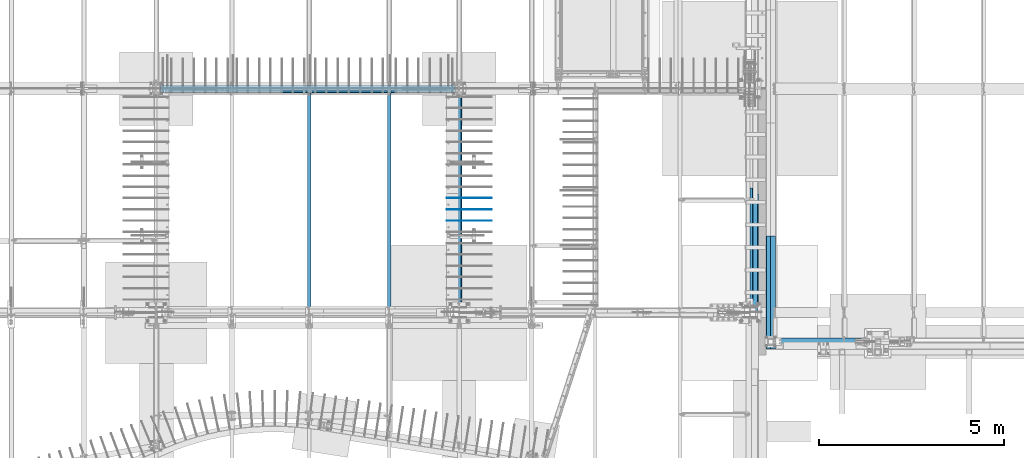
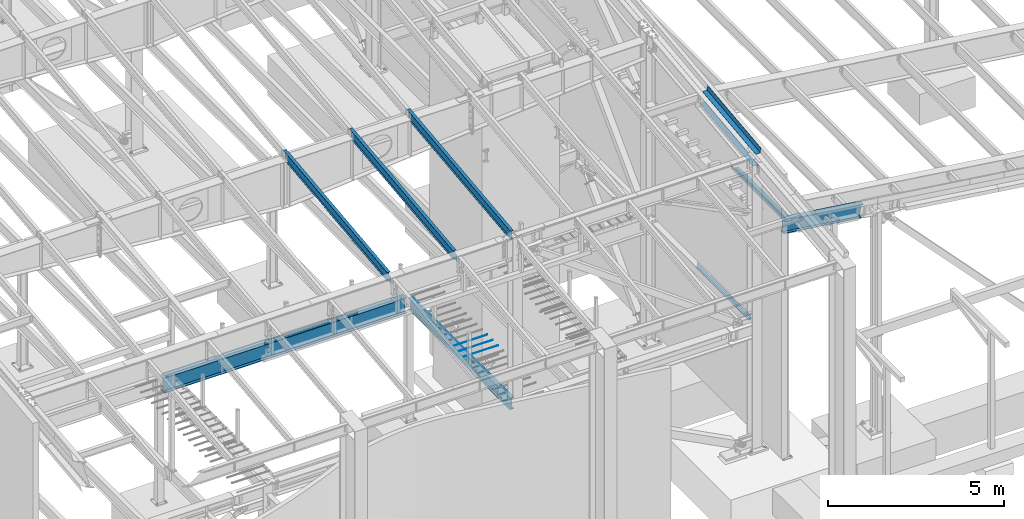
# One storey, part 717 of 1179: 15 beams, 13 elements without a shape of their own.
"""IFC2X3 building model written with IfcOpenShell, lengths in millimetres."""

from ifc_helpers import new_model, si_unit, frame, origin_with_axes, place, context, subcontext, project, spatial, faceted_brep, material, type_object, element, aggregate, save


model = new_model("IFC2X3")

# Units and contexts
model_context = context("Model", 3, precision=1e-05, world=origin_with_axes())
body_context = subcontext(model_context, "Body", "Model", "MODEL_VIEW")
ifc_project = project(units=[si_unit("LENGTHUNIT", "METRE", prefix="MILLI"), si_unit("AREAUNIT", "SQUARE_METRE"), si_unit("VOLUMEUNIT", "CUBIC_METRE"), si_unit("MASSUNIT", "GRAM", prefix="KILO"), si_unit("TIMEUNIT", "SECOND"), si_unit("PLANEANGLEUNIT", "RADIAN"), si_unit("SOLIDANGLEUNIT", "STERADIAN"), si_unit("THERMODYNAMICTEMPERATUREUNIT", "DEGREE_CELSIUS"), si_unit("LUMINOUSINTENSITYUNIT", "LUMEN")], contexts=[model_context])

# Site, building, storey
site_placement = place(None, origin_with_axes())
site = spatial("IfcSite", under=ifc_project, at=site_placement, CompositionType="ELEMENT")
building_placement = place(site_placement, origin_with_axes())
building = spatial("IfcBuilding", under=site, at=building_placement, Name="Undefined", CompositionType="ELEMENT")
storey_placement = place(building_placement, origin_with_axes())
storey = spatial("IfcBuildingStorey", under=building, at=storey_placement, Name="Undefined", CompositionType="ELEMENT", Elevation=0.0)

# Assembly, beam
assembly_1_placement = place(storey_placement, origin_with_axes())
assembly_1 = element("IfcElementAssembly", 1, at=assembly_1_placement, inside=storey, Name="BEAM", AssemblyPlace="NOTDEFINED", PredefinedType="RIGID_FRAME")
ifc_material_1 = material(Name="STEEL/A992")
beam_type_1 = type_object("IfcBeamType", Name="W12X14", PredefinedType="NOTDEFINED")
beam_1_placement = place(assembly_1_placement, frame((16459.2, 5452.5431792468, 9711.23798851528), z_axis=(0.0, -0.112284087038017, 0.993676146336441), x_axis=(0.0, 0.993676146336441, 0.112284087038017)))
beam_1 = element("IfcBeam", 2, at=beam_1_placement, type_object=beam_type_1, material=ifc_material_1, Name="BEAM", ObjectType="W12X14", context=body_context, shape_type="Brep", body=[
    faceted_brep([(170.216585454447, -50.7999999999993, 144.462499999847), (170.216585454447, -2.38124999999854, 144.462499999847), (6076.55490468175, -2.38124999999854, 144.462499996846), (6076.55490468175, -50.7999999999993, 144.462499996846), (170.934127035087, -50.7999999999993, 150.812499999844), (6077.27244626239, -50.7999999999993, 150.812499996842), (170.934127035087, 50.7999999999993, 150.812499999844), (6077.27244626239, 50.7999999999993, 150.812499996842), (170.216585454447, 50.7999999999993, 144.462499999847), (6076.55490468175, 50.7999999999993, 144.462499996846), (170.216585454447, 2.38124999999854, 144.462499999847), (6076.55490468175, 2.38124999999854, 144.462499996846), (136.850901954715, -50.7999999999993, -150.812500000002), (137.568443535355, -50.7999999999993, -144.462500000003), (137.568443535355, -2.38124999999854, -144.462500000003), (167.568473799025, 2.38124999999854, 121.027608607305), (141.675763328272, 2.38124999999854, -108.114110737644), (137.568443535355, 2.38124999999854, -144.462500000003), (137.568443535355, 50.7999999999993, -144.462500000003), (136.850901954715, 50.7999999999993, -150.812500000002), (5871.37503272928, 2.38124783346939, -144.462500002968), (5871.37503272929, 50.7999999999993, -144.462500002917), (5870.65749114864, 50.7999999999993, -150.812500002912), (5870.65749114864, -50.7999999999993, -150.812500002912), (5871.37503272929, -50.7999999999993, -144.462500002917), (5871.37503272929, -2.38124999999854, -144.462500002917), (5874.19845246322, -2.38124999999854, -119.476191482236), (5875.70477851863, -2.38124999999854, -114.755394783042), (5878.90301301472, -2.38124999999854, -110.970393360541), (5883.30625374162, -2.38124999999854, -108.697419370077), (5888.24414721426, -2.38124999999854, -108.282512497075), (6045.98095926941, -2.38124999999854, -126.106563095373), (6045.98095929506, 2.38124999999854, -126.10656309827), (5883.30625374162, 2.38122766974266, -108.697419370077), (5878.90301301472, 2.38122737693629, -110.970393360541), (5875.70477851863, 2.38122688934163, -114.755394783042), (5874.19845246322, 2.38122628119891, -119.476191482236), (5888.24414721426, 2.38122772319184, -108.282512497075)], [[[0, 1, 2, 3]], [[4, 0, 3, 5]], [[6, 4, 5, 7]], [[8, 6, 7, 9]], [[10, 8, 9, 11]], [[12, 13, 14, 1, 0, 4, 6, 8, 10, 15, 16, 17, 18, 19]], [[18, 17, 20, 21]], [[19, 18, 21, 22]], [[12, 19, 22, 23]], [[13, 12, 23, 24]], [[14, 13, 24, 25]], [[2, 1, 14, 25, 26, 27, 28, 29, 30, 31]], [[11, 9, 7, 5, 3, 2, 31, 32]], [[33, 34, 35, 36, 20, 17, 16, 15, 10, 11, 32, 37]], [[31, 30, 37, 32]], [[29, 33, 37, 30]], [[28, 34, 33, 29]], [[27, 35, 34, 28]], [[26, 36, 35, 27]], [[25, 24, 23, 22, 21, 20, 36, 26]]]),
])
aggregate(assembly_1, [beam_1])

assembly_2_placement = place(storey_placement, origin_with_axes())
assembly_2 = element("IfcElementAssembly", 3, at=assembly_2_placement, inside=storey, Name="BEAM", AssemblyPlace="NOTDEFINED", PredefinedType="RIGID_FRAME")
beam_2_placement = place(assembly_2_placement, frame((14566.9, 5452.5431792468, 9711.23798851528), z_axis=(0.0, -0.112284087038017, 0.993676146336441), x_axis=(0.0, 0.993676146336441, 0.112284087038017)))
beam_2 = element("IfcBeam", 4, at=beam_2_placement, type_object=beam_type_1, material=ifc_material_1, Name="BEAM", ObjectType="W12X14", context=body_context, shape_type="Brep", body=[
    faceted_brep([(-14.1944481268274, -2.38125000000036, -144.462499999927), (-14.9119897074661, -2.38115214811296, -150.812499999925), (137.488001223044, -2.38117577009325, -150.8125), (137.488001223013, -2.38125000000036, -144.462500000003), (137.48799371822, -50.7999999999993, -144.462500000005), (137.487993718216, -50.7999999999993, -150.812500000002), (5871.37503272929, 50.7999999999993, -144.462500002917), (5870.65749114864, 50.7999999999993, -150.812500002912), (137.488009517103, 50.7999999999993, -150.812500000002), (137.488009517107, 50.7999999999993, -144.462500000003), (137.488002012233, 2.3811758245356, -144.462500001737), (137.488002012265, 2.38132415558357, -150.812500000002), (-14.9119897074661, 2.38134777762207, -150.812499999925), (-14.1944481268274, 2.38125000000036, -144.462499999927), (5871.37503272928, 2.38124783346939, -144.462500002968), (6076.55490468175, 2.38124999999854, 144.462499996846), (6076.55490468175, 50.7999999999993, 144.462499996846), (6077.27244626239, 50.7999999999993, 150.812499996842), (6077.27244626239, -50.7999999999993, 150.812499996842), (6076.55490468175, -50.7999999999993, 144.462499996846), (6076.55490468175, -2.38124999999854, 144.462499996846), (6045.98095926941, -2.38124999999854, -126.106563095373), (6045.98095929506, 2.38124999999854, -126.10656309827), (5888.24414721426, -2.38124999999854, -108.282512497075), (5888.24414721426, 2.38122772319184, -108.282512497075), (5883.30625374162, -2.38124999999854, -108.697419370077), (5883.30625374162, 2.38122766974266, -108.697419370077), (5878.90301301472, -2.38124999999854, -110.970393360541), (5878.90301301472, 2.38122737693629, -110.970393360541), (5875.70477851863, -2.38124999999854, -114.755394783042), (5875.70477851863, 2.38122688934163, -114.755394783042), (5874.19845246322, -2.38124999999854, -119.476191482236), (5874.19845246322, 2.38122628119891, -119.476191482236), (5871.37503272929, -2.38124999999854, -144.462500002917), (5871.37503272929, -50.7999999999993, -144.462500002917), (5870.65749114864, -50.7999999999993, -150.812500002912), (-13.929041623056, -2.38125000000036, -142.113742318956), (12.2064158412222, -2.38125000000036, 89.176205714708), (12.2064158412222, 2.38125000000036, 89.176205714708), (-13.9290290466961, 2.38125000000036, -142.113631022425), (125.78359955719, -2.38125000000036, 76.342134544826), (125.78359955719, 2.38125000000036, 76.342134544826), (130.721493030343, -2.38125000000036, 76.7570414172296), (130.721493030343, 2.38125000000036, 76.7570414172296), (135.124733757862, -2.38125000000036, 79.0300154074976), (135.124733757862, 2.38125000000036, 79.0300154074976), (138.322968254461, -2.38125000000036, 82.8150168301745), (138.322968254461, 2.38125000000036, 82.8150168301745), (139.829294310099, -2.38125000000036, 87.5358135297793), (139.829294310099, 2.38125000000036, 87.5358135297793), (146.26193440305, 2.38125000000036, 144.46249999986), (146.26193440305, 50.7999999999993, 144.46249999986), (146.979475983694, 50.7999999999993, 150.812499999854), (146.979475983694, -50.7999999999993, 150.812499999854), (146.26193440305, -50.7999999999993, 144.46249999986), (146.26193440305, -2.38125000000036, 144.46249999986)], [[[0, 1, 2, 3]], [[4, 3, 2, 5]], [[6, 7, 8, 9]], [[10, 11, 12, 13]], [[9, 8, 11, 10]], [[14, 6, 9, 10]], [[15, 16, 17, 18, 19, 20, 21, 22]], [[21, 23, 24, 22]], [[25, 26, 24, 23]], [[27, 28, 26, 25]], [[29, 30, 28, 27]], [[31, 32, 30, 29]], [[33, 34, 35, 7, 6, 14, 32, 31]], [[35, 34, 4, 5]], [[1, 12, 11, 8, 7, 35, 5, 2]], [[36, 37, 38, 39, 13, 12, 1, 0]], [[40, 41, 38, 37]], [[42, 43, 41, 40]], [[44, 45, 43, 42]], [[46, 47, 45, 44]], [[48, 49, 47, 46]], [[15, 22, 24, 26, 28, 30, 32, 14, 10, 13, 39, 38, 41, 43, 45, 47, 49, 50]], [[16, 15, 50, 51]], [[17, 16, 51, 52]], [[18, 17, 52, 53]], [[19, 18, 53, 54]], [[20, 19, 54, 55]], [[53, 52, 51, 50, 49, 48, 55, 54]], [[46, 44, 42, 40, 37, 36, 0, 3, 33, 31, 29, 27, 25, 23, 21, 20, 55, 48]], [[34, 33, 3, 4]]]),
])
aggregate(assembly_2, [beam_2])

assembly_3_placement = place(storey_placement, origin_with_axes())
assembly_3 = element("IfcElementAssembly", 5, at=assembly_3_placement, inside=storey, Name="BEAM", AssemblyPlace="NOTDEFINED", PredefinedType="RIGID_FRAME")
beam_3_placement = place(assembly_3_placement, frame((12407.9, 5452.5431792468, 9711.23798851528), z_axis=(0.0, -0.112284087038017, 0.993676146336441), x_axis=(0.0, 0.993676146336441, 0.112284087038017)))
beam_3 = element("IfcBeam", 6, at=beam_3_placement, type_object=beam_type_1, material=ifc_material_1, Name="BEAM", ObjectType="W12X14", context=body_context, shape_type="Brep", body=[
    faceted_brep([(-14.1944481268274, -2.38125000000036, -144.462499999927), (-14.9119897074661, -2.38115214811296, -150.812499999925), (137.488001223044, -2.38117577009325, -150.8125), (137.488001223013, -2.38125000000036, -144.462500000003), (137.48799371822, -50.7999999999993, -144.462500000005), (137.487993718216, -50.7999999999993, -150.812500000002), (5871.37503272929, 50.7999999999993, -144.462500002917), (5870.65749114864, 50.7999999999993, -150.812500002912), (137.488009517103, 50.7999999999993, -150.812500000002), (137.488009517107, 50.7999999999993, -144.462500000003), (137.488002012233, 2.3811758245356, -144.462500001737), (137.488002012265, 2.38132415558357, -150.812500000002), (-14.9119897074661, 2.38134777762207, -150.812499999925), (-14.1944481268274, 2.38125000000036, -144.462499999927), (5871.37503272928, 2.38124783346939, -144.462500002968), (6076.55490468175, 2.38124999999854, 144.462499996846), (6076.55490468175, 50.7999999999993, 144.462499996846), (6077.27244626239, 50.7999999999993, 150.812499996842), (6077.27244626239, -50.7999999999993, 150.812499996842), (6076.55490468175, -50.7999999999993, 144.462499996846), (6076.55490468175, -2.38124999999854, 144.462499996846), (6045.98095926941, -2.38124999999854, -126.106563095373), (6045.98095929506, 2.38124999999854, -126.10656309827), (5888.24414721426, -2.38124999999854, -108.282512497075), (5888.24414721426, 2.38122772319184, -108.282512497075), (5883.30625374162, -2.38124999999854, -108.697419370077), (5883.30625374162, 2.38122766974266, -108.697419370077), (5878.90301301472, -2.38124999999854, -110.970393360541), (5878.90301301472, 2.38122737693629, -110.970393360541), (5875.70477851863, -2.38124999999854, -114.755394783042), (5875.70477851863, 2.38122688934163, -114.755394783042), (5874.19845246322, -2.38124999999854, -119.476191482236), (5874.19845246322, 2.38122628119891, -119.476191482236), (5871.37503272929, -2.38124999999854, -144.462500002917), (5871.37503272929, -50.7999999999993, -144.462500002917), (5870.65749114864, -50.7999999999993, -150.812500002912), (-13.929041623056, -2.38125000000036, -142.113742318956), (12.2064158412222, -2.38125000000036, 89.176205714708), (12.2064158412222, 2.38125000000036, 89.176205714708), (-13.9290290466961, 2.38125000000036, -142.113631022425), (125.78359955719, -2.38125000000036, 76.342134544826), (125.78359955719, 2.38125000000036, 76.342134544826), (130.721493030343, -2.38125000000036, 76.7570414172296), (130.721493030343, 2.38125000000036, 76.7570414172296), (135.124733757862, -2.38125000000036, 79.0300154074976), (135.124733757862, 2.38125000000036, 79.0300154074976), (138.322968254461, -2.38125000000036, 82.8150168301745), (138.322968254461, 2.38125000000036, 82.8150168301745), (139.829294310099, -2.38125000000036, 87.5358135297793), (139.829294310099, 2.38125000000036, 87.5358135297793), (146.26193440305, 2.38125000000036, 144.46249999986), (146.26193440305, 50.7999999999993, 144.46249999986), (146.979475983694, 50.7999999999993, 150.812499999854), (146.979475983694, -50.7999999999993, 150.812499999854), (146.26193440305, -50.7999999999993, 144.46249999986), (146.26193440305, -2.38125000000036, 144.46249999986)], [[[0, 1, 2, 3]], [[4, 3, 2, 5]], [[6, 7, 8, 9]], [[10, 11, 12, 13]], [[9, 8, 11, 10]], [[14, 6, 9, 10]], [[15, 16, 17, 18, 19, 20, 21, 22]], [[21, 23, 24, 22]], [[25, 26, 24, 23]], [[27, 28, 26, 25]], [[29, 30, 28, 27]], [[31, 32, 30, 29]], [[33, 34, 35, 7, 6, 14, 32, 31]], [[35, 34, 4, 5]], [[1, 12, 11, 8, 7, 35, 5, 2]], [[36, 37, 38, 39, 13, 12, 1, 0]], [[40, 41, 38, 37]], [[42, 43, 41, 40]], [[44, 45, 43, 42]], [[46, 47, 45, 44]], [[48, 49, 47, 46]], [[15, 22, 24, 26, 28, 30, 32, 14, 10, 13, 39, 38, 41, 43, 45, 47, 49, 50]], [[16, 15, 50, 51]], [[17, 16, 51, 52]], [[18, 17, 52, 53]], [[19, 18, 53, 54]], [[20, 19, 54, 55]], [[53, 52, 51, 50, 49, 48, 55, 54]], [[46, 44, 42, 40, 37, 36, 0, 3, 33, 31, 29, 27, 25, 23, 21, 20, 55, 48]], [[34, 33, 3, 4]]]),
])
aggregate(assembly_3, [beam_3])

assembly_4_placement = place(storey_placement, origin_with_axes())
assembly_4 = element("IfcElementAssembly", 7, at=assembly_4_placement, inside=storey, Name="BEAM", AssemblyPlace="NOTDEFINED", PredefinedType="RIGID_FRAME")
beam_type_2 = type_object("IfcBeamType", Name="W16X31", PredefinedType="NOTDEFINED")
beam_4_placement = place(assembly_4_placement, frame((16459.2, 5429.25, 3900.4875), z_axis=(0.0, 0.0, 1.0), x_axis=(0.0, 1.0, 0.0)))
beam_4 = element("IfcBeam", 8, at=beam_4_placement, type_object=beam_type_2, material=ifc_material_1, Name="BEAM", ObjectType="W16X31", context=body_context, shape_type="Brep", body=[
    faceted_brep([(176.212499999999, -69.8499999999985, -190.5), (176.212499999999, -69.8499999999985, -201.6125), (5937.25, -69.8499999999985, -201.6125), (5937.25, -69.8499999999985, -190.5), (176.212499999999, -3.17499999999927, -190.5), (5937.25, -3.17499999999927, -190.5), (176.212500000009, -3.17499999999927, 190.5), (5937.25, -3.17499999999927, 190.5), (176.212500000009, -69.8500000000004, 190.5), (5937.25, -69.8499999999985, 190.5), (176.212500000009, -69.8500000000004, 201.6125), (5937.25, -69.8499999999985, 201.6125), (176.212500000009, 69.8500000000004, 201.6125), (5937.25, 69.8499999999985, 201.6125), (176.212500000009, 69.8500000000004, 190.5), (5937.25, 69.8499999999985, 190.5), (176.212500000009, 3.17499999999927, 190.5), (5937.25, 3.17499999999927, 190.5), (176.212499999999, 3.17499999999927, -190.5), (5937.25, 3.17499999999927, -190.5), (176.212500000001, 69.8500000000004, -190.5), (5937.25, 69.8499999999985, -190.5), (176.212500000001, 69.8500000000004, -201.6125), (5937.25, 69.8499999999985, -201.6125)], [[[0, 1, 2, 3]], [[4, 0, 3, 5]], [[6, 4, 5, 7]], [[8, 6, 7, 9]], [[10, 8, 9, 11]], [[12, 10, 11, 13]], [[14, 12, 13, 15]], [[16, 14, 15, 17]], [[18, 16, 17, 19]], [[20, 18, 19, 21]], [[1, 0, 4, 6, 8, 10, 12, 14, 16, 18, 20, 22]], [[1, 22, 23, 2]], [[19, 17, 15, 13, 11, 9, 7, 5, 3, 2, 23, 21]], [[22, 20, 21, 23]]]),
])
aggregate(assembly_4, [beam_4])

assembly_5_placement = place(storey_placement, origin_with_axes())
assembly_5 = element("IfcElementAssembly", 9, at=assembly_5_placement, inside=storey, Name="BEAM", AssemblyPlace="NOTDEFINED", PredefinedType="RIGID_FRAME")
ifc_material_2 = material(Name="STEEL/A36")
beam_type_3 = type_object("IfcBeamType", PredefinedType="NOTDEFINED")
beam_5_placement = place(assembly_5_placement, frame((24350.663, 6952.10322718026, 10035.6537774302), z_axis=(0.0, -0.993676146336441, -0.112284087038017), x_axis=(1.0, 0.0, 0.0)))
beam_5 = element("IfcBeam", 10, at=beam_5_placement, type_object=beam_type_3, material=ifc_material_2, Name="BENT_PLATE", context=body_context, shape_type="Brep", body=[
    faceted_brep([(0.0, -3.17499999999927, -1524.0), (6.00266503170133e-10, -3.17499999922438, 1524.00000000052), (6.00266503170133e-10, 3.17500000077416, 1524.00000000052), (0.0, 3.17499999999927, -1524.0), (153.987000024775, 3.17499999922438, 1524.00000000046), (153.987000022519, 3.17500000077052, -1524.00000000059), (160.337000000047, -3.17500000061591, -1523.99999999915), (160.336999999981, -3.17499999938082, 1523.99999999915), (153.987000000016, 187.325000000103, 1523.99999999907), (153.987000000016, 187.324999998867, -1523.99999999923), (160.337000000014, 187.325000000103, 1523.99999999907), (160.337000000014, 187.324999998867, -1523.99999999923)], [[[0, 1, 2, 3]], [[3, 2, 4, 5]], [[1, 0, 6, 7]], [[5, 4, 8, 9]], [[4, 2, 1, 7, 10, 8]], [[7, 6, 11, 10]], [[6, 0, 3, 5, 9, 11]], [[10, 11, 9, 8]]]),
])

assembly_6_placement = place(storey_placement, origin_with_axes())
assembly_6 = element("IfcElementAssembly", 11, at=assembly_6_placement, inside=storey, Name="BEAM", AssemblyPlace="NOTDEFINED", PredefinedType="RIGID_FRAME")
beam_type_4 = type_object("IfcBeamType", PredefinedType="NOTDEFINED")
beam_6_placement = place(assembly_6_placement, frame((24313.3562424324, 7281.86250373758, 3935.41250614813), z_axis=(0.0, 1.0, 0.0), x_axis=(1.0, 0.0, 0.0)))
beam_6 = element("IfcBeam", 12, at=beam_6_placement, type_object=beam_type_4, material=ifc_material_2, Name="BENT_PLATE", context=body_context, shape_type="Brep", body=[
    faceted_brep([(0.0, -3.17499999999927, -1524.0), (6.00266503170133e-10, -3.17499999922438, 1524.00000000052), (6.00266503170133e-10, 3.17500000077416, 1524.00000000052), (0.0, 3.17499999999927, -1524.0), (72.2312502115165, 3.17500000827522, 1524.0000000001), (72.2312502114401, 3.17500000827522, -1523.9999999999), (65.8812496717219, -3.17499999245229, -1523.99999999991), (65.8812496717983, -3.17499999245229, 1524.00000000009), (72.2312372589367, -149.224999780281, 1524.00000000016), (72.2312372574052, -149.224999781581, -1523.99999999984), (65.8812372589382, -149.224999240552, 1524.00000000016), (65.8812372574066, -149.224999241851, -1523.99999999984)], [[[0, 1, 2, 3]], [[3, 2, 4, 5]], [[1, 0, 6, 7]], [[5, 4, 8, 9]], [[4, 2, 1, 7, 10, 8]], [[7, 6, 11, 10]], [[6, 0, 3, 5, 9, 11]], [[10, 11, 9, 8]]]),
])
aggregate(assembly_6, [beam_6])

assembly_7_placement = place(storey_placement, origin_with_axes())
assembly_7 = element("IfcElementAssembly", 13, at=assembly_7_placement, inside=storey, Name="BEAM", AssemblyPlace="NOTDEFINED", PredefinedType="RIGID_FRAME")
beam_type_5 = type_object("IfcBeamType", PredefinedType="NOTDEFINED")
beam_7_placement = place(assembly_7_placement, frame((13198.475, 11372.85, 4235.45000610352), z_axis=(1.0, 0.0, 0.0), x_axis=(0.0, 0.0, -1.0)))
beam_7 = element("IfcBeam", 14, at=beam_7_placement, type_object=beam_type_5, material=ifc_material_2, Name="BENT_PLATE", context=body_context, shape_type="Brep", body=[
    faceted_brep([(133.350006103517, 47.6249992370613, 1317.625), (127.000006103516, 47.6249992370613, 1317.625), (127.000006103516, 3.17499999999927, 1317.625), (133.350006103517, 3.17499999999745, 1317.625), (133.350006103517, 3.17499999999745, 1419.225), (127.000006103516, 3.17499999999927, 1419.225), (127.000006103516, 47.6249992370613, 1419.225), (133.350006103517, 47.6249992370613, 1419.225), (6.00266503170133e-10, -3.17499999922438, 1524.00000000052), (0.0, -3.17499999999927, -1524.0), (133.350006103517, -3.17499999999927, -1524.0), (133.350006103517, -3.17499999999927, 1524.0), (127.000006103516, 3.17499999999927, 1524.0), (127.000006103516, 47.6249992370613, 1524.0), (133.350006103517, 47.6249992370613, 1524.0), (6.00266503170133e-10, 3.17500000077416, 1524.00000000052), (0.0, 3.17499999999927, 1317.625), (0.0, 3.17499999999927, -739.775), (0.0, 3.17499999999927, -841.375000000002), (0.0, 3.17499999999927, -1524.0), (0.0, 3.17499999999927, 1419.225), (127.000006103516, 3.17499999999927, -1524.0), (127.000006103516, 47.6249992370613, -1524.0), (133.350006103517, 47.6249992370613, -1524.0), (127.000006103516, 47.6249992370613, -841.375000000002), (133.350006103517, 47.6249992370613, -841.375000000002), (133.350006103517, 3.17500000000109, -739.775), (127.000006103516, 3.17499999999927, -739.775), (127.000006103516, 47.6249992370613, -739.775), (133.350006103517, 47.6249992370613, -739.775), (133.350006103517, 3.17500000000109, -841.375000000002), (127.000006103516, 3.17499999999927, -841.375000000002)], [[[0, 1, 2, 3]], [[4, 5, 6, 7]], [[3, 2, 5, 4]], [[8, 9, 10, 11]], [[12, 13, 6, 5]], [[13, 14, 7, 6]], [[12, 15, 8, 11, 14, 13]], [[16, 17, 18, 19, 9, 8, 15, 20]], [[10, 9, 19, 21, 22, 23]], [[23, 22, 24, 25]], [[26, 27, 28, 29]], [[30, 31, 27, 26]], [[25, 24, 31, 30]], [[22, 21, 31, 24]], [[19, 18, 17, 16, 20, 15, 12, 5, 2, 27, 31, 21]], [[28, 27, 2, 1]], [[29, 28, 1, 0]], [[14, 11, 10, 23, 25, 30, 26, 29, 0, 3, 4, 7]]]),
])

# Beam
beam_type_6 = type_object("IfcBeamType", PredefinedType="NOTDEFINED")
beam_8_placement = place(assembly_5_placement, frame((24350.6629994128, 7120.17352067369, 9525.83951974278), z_axis=(0.0, -0.993676146336441, -0.112284087038017), x_axis=(1.0, 0.0, 0.0)))
beam_8 = element("IfcBeam", 15, at=beam_8_placement, type_object=beam_type_6, material=ifc_material_2, Name="BENT_PLATE", context=body_context, shape_type="Brep", body=[
    faceted_brep([(62.7057505860175, -3.17499999968459, -1423.81983398082), (62.7057505860175, 3.17500000031032, -1423.81983398081), (-1.79716153070331e-09, 3.17499999927713, -1423.81983398073), (-1.69166014529765e-09, -3.17500000071959, -1423.81983398073), (62.7057505860175, -3.17499999967549, -1404.76983398105), (62.7057505860175, 3.17500000032123, -1404.76983398105), (-1.6698322724551e-09, -3.1750000007105, -1404.76983398107), (-1.77533365786076e-09, 3.17499999928805, -1404.76983398107), (179.387000000001, -3.17499999999927, 1524.0), (179.387000000001, -3.17499999999927, -1524.0), (179.387000202249, -136.524999793119, -1523.99999999991), (179.38700020294, -136.524999792508, 1523.99999999976), (185.737000000001, 3.17499999999927, 1524.0), (6.00266503170133e-10, 3.17500000077416, 1524.00000000052), (6.00266503170133e-10, -3.17499999922438, 1524.00000000052), (185.737000202938, -136.524999792508, 1523.99999999976), (185.737000000001, 3.17499999999927, -1524.0), (185.737000202247, -136.524999793119, -1523.99999999991), (0.0, -3.17499999999927, -1524.0), (0.0, 3.17499999999927, -1524.0)], [[[0, 1, 2, 3]], [[4, 5, 1, 0]], [[6, 7, 5, 4]], [[8, 9, 10, 11]], [[12, 13, 14, 8, 11, 15]], [[16, 12, 15, 17]], [[11, 10, 17, 15]], [[9, 18, 19, 16, 17, 10]], [[19, 18, 3, 2]], [[13, 12, 16, 19, 2, 1, 5, 7]], [[14, 13, 7, 6]], [[3, 18, 9, 8, 14, 6, 4, 0]]]),
])

aggregate(assembly_5, [beam_5, beam_8])

# Assembly, beam
assembly_8_placement = place(storey_placement, origin_with_axes())
assembly_8 = element("IfcElementAssembly", 16, at=assembly_8_placement, inside=storey, Name="PLATE", AssemblyPlace="NOTDEFINED", PredefinedType="RIGID_FRAME")
beam_type_7 = type_object("IfcBeamType", PredefinedType="NOTDEFINED")
beam_9_placement = place(assembly_8_placement, frame((24880.9652345644, 4457.69999999963, 7964.0487255808), z_axis=(-0.99100656978554, 0.0, 0.133813222971043), x_axis=(0.0, 1.0, 0.0)))
beam_9 = element("IfcBeam", 17, at=beam_9_placement, type_object=beam_type_7, material=ifc_material_2, Name="PLATE", context=body_context, shape_type="Brep", body=[
    faceted_brep([(0.0, 4.76249999999709, -114.3), (0.0, 4.76249999999709, 114.3), (3048.0, 4.76249999996799, 114.300000000025), (3048.0, 4.76250000002983, -114.300000000025), (0.0, -4.76249999999709, 114.3), (3048.0, -4.76250000003711, 114.300000000014), (0.0, -4.76249999999709, -114.3), (3048.0, -4.76249999997344, -114.300000000036)], [[[0, 1, 2, 3]], [[1, 4, 5, 2]], [[4, 6, 7, 5]], [[6, 0, 3, 7]], [[5, 7, 3, 2]], [[6, 4, 1, 0]]]),
])
aggregate(assembly_8, [beam_9])

assembly_9_placement = place(storey_placement, origin_with_axes())
assembly_9 = element("IfcElementAssembly", 18, at=assembly_9_placement, inside=storey, Name="BENT_PLATE", AssemblyPlace="NOTDEFINED", PredefinedType="RIGID_FRAME")
beam_type_8 = type_object("IfcBeamType", PredefinedType="NOTDEFINED")
beam_10_placement = place(assembly_9_placement, frame((24744.362499997, 5981.69999999963, 8102.29217706219), z_axis=(0.0, 1.0, 0.0), x_axis=(0.0, 0.0, -1.0)))
beam_10 = element("IfcBeam", 19, at=beam_10_placement, type_object=beam_type_8, material=ifc_material_2, Name="BENT_PLATE", context=body_context, shape_type="Brep", body=[
    faceted_brep([(-2.91038304567337e-11, -4.76250000000073, -1524.0), (-2.91038304567337e-11, -4.76250000000073, 1524.0), (2.91038304567337e-11, 4.76250000000073, 1524.0), (2.91038304567337e-11, 4.76250000000073, -1524.0), (114.300008765535, 4.76250001759399, 1524.0000000001), (114.300003051474, 4.7625000005828, -1524.0), (105.977955544956, -4.76249999945867, -1524.0), (105.977955544956, -4.76249999945867, 1524.0), (131.343048095475, -121.088742065571, 1524.0), (131.343048095475, -121.088742065571, -1524.0), (121.904205090902, -122.366970423507, 1524.0), (121.904205090902, -122.366970423507, -1524.0)], [[[0, 1, 2, 3]], [[3, 2, 4, 5]], [[1, 0, 6, 7]], [[5, 4, 8, 9]], [[4, 2, 1, 7, 10, 8]], [[7, 6, 11, 10]], [[6, 0, 3, 5, 9, 11]], [[10, 11, 9, 8]]]),
])
aggregate(assembly_9, [beam_10])

assembly_10_placement = place(storey_placement, origin_with_axes())
assembly_10 = element("IfcElementAssembly", 20, at=assembly_10_placement, inside=storey, Name="#4 DOWEL", AssemblyPlace="NOTDEFINED", PredefinedType="NOTDEFINED")
ifc_material_3 = material(Name="REBAR/A615-40")
beam_type_9 = type_object("IfcBeamType", Name="#4 DOWEL", PredefinedType="NOTDEFINED")
beam_11_placement = place(assembly_10_placement, frame((16119.475, 8524.875, 4203.70000610352), z_axis=(0.0, 0.0, 1.0), x_axis=(1.0, 0.0, 0.0)))
beam_11 = element("IfcBeam", 21, at=beam_11_placement, type_object=beam_type_9, material=ifc_material_3, Name="#4 DOWEL", ObjectType="#4 DOWEL", context=body_context, shape_type="Brep", body=[
    faceted_brep([(0.0, -6.34999999999854, 0.0), (0.0, -4.49012806053361, -4.49012806053452), (1219.2, -4.49012806053543, -4.49012806053452), (1219.2, -6.35000000000036, 0.0), (0.0, 0.0, -6.34999999999991), (1219.2, 0.0, -6.35000000000036), (0.0, 4.49012806053361, -4.49012806053452), (1219.2, 4.49012806053543, -4.49012806053452), (0.0, 6.34999999999854, 0.0), (1219.2, 6.35000000000036, 0.0), (0.0, 4.49012806053361, 4.49012806053452), (1219.2, 4.49012806053543, 4.49012806053452), (0.0, 0.0, 6.34999999999991), (1219.2, 0.0, 6.35000000000036), (0.0, -4.49012806053361, 4.49012806053452), (1219.2, -4.49012806053543, 4.49012806053452)], [[[0, 1, 2, 3]], [[1, 4, 5, 2]], [[4, 6, 7, 5]], [[6, 8, 9, 7]], [[8, 10, 11, 9]], [[10, 12, 13, 11]], [[12, 14, 15, 13]], [[14, 0, 3, 15]], [[5, 7, 9, 11, 13, 15, 3, 2]], [[14, 12, 10, 8, 6, 4, 1, 0]]]),
])
aggregate(assembly_10, [beam_11])

assembly_11_placement = place(storey_placement, origin_with_axes())
assembly_11 = element("IfcElementAssembly", 22, at=assembly_11_placement, inside=storey, Name="#4 DOWEL", AssemblyPlace="NOTDEFINED", PredefinedType="NOTDEFINED")
beam_12_placement = place(assembly_11_placement, frame((16119.475, 8220.075, 4203.70000610352), z_axis=(0.0, 0.0, 1.0), x_axis=(1.0, 0.0, 0.0)))
beam_12 = element("IfcBeam", 23, at=beam_12_placement, type_object=beam_type_9, material=ifc_material_3, Name="#4 DOWEL", ObjectType="#4 DOWEL", context=body_context, shape_type="Brep", body=[
    faceted_brep([(0.0, -6.34999999999854, 0.0), (0.0, -4.49012806053361, -4.49012806053452), (1219.2, -4.49012806053543, -4.49012806053452), (1219.2, -6.35000000000036, 0.0), (0.0, 0.0, -6.34999999999991), (1219.2, 0.0, -6.35000000000036), (0.0, 4.49012806053361, -4.49012806053452), (1219.2, 4.49012806053543, -4.49012806053452), (0.0, 6.34999999999854, 0.0), (1219.2, 6.35000000000036, 0.0), (0.0, 4.49012806053361, 4.49012806053452), (1219.2, 4.49012806053543, 4.49012806053452), (0.0, 0.0, 6.34999999999991), (1219.2, 0.0, 6.35000000000036), (0.0, -4.49012806053361, 4.49012806053452), (1219.2, -4.49012806053543, 4.49012806053452)], [[[0, 1, 2, 3]], [[1, 4, 5, 2]], [[4, 6, 7, 5]], [[6, 8, 9, 7]], [[8, 10, 11, 9]], [[10, 12, 13, 11]], [[12, 14, 15, 13]], [[14, 0, 3, 15]], [[5, 7, 9, 11, 13, 15, 3, 2]], [[14, 12, 10, 8, 6, 4, 1, 0]]]),
])
aggregate(assembly_11, [beam_12])

assembly_12_placement = place(storey_placement, origin_with_axes())
assembly_12 = element("IfcElementAssembly", 24, at=assembly_12_placement, inside=storey, Name="#4 DOWEL", AssemblyPlace="NOTDEFINED", PredefinedType="NOTDEFINED")
beam_13_placement = place(assembly_12_placement, frame((16119.475, 7915.275, 4203.70000610352), z_axis=(0.0, 0.0, 1.0), x_axis=(1.0, 0.0, 0.0)))
beam_13 = element("IfcBeam", 25, at=beam_13_placement, type_object=beam_type_9, material=ifc_material_3, Name="#4 DOWEL", ObjectType="#4 DOWEL", context=body_context, shape_type="Brep", body=[
    faceted_brep([(0.0, -6.34999999999854, 0.0), (0.0, -4.49012806053361, -4.49012806053452), (1219.2, -4.49012806053543, -4.49012806053452), (1219.2, -6.35000000000036, 0.0), (0.0, 0.0, -6.34999999999991), (1219.2, 0.0, -6.35000000000036), (0.0, 4.49012806053361, -4.49012806053452), (1219.2, 4.49012806053543, -4.49012806053452), (0.0, 6.34999999999854, 0.0), (1219.2, 6.35000000000036, 0.0), (0.0, 4.49012806053361, 4.49012806053452), (1219.2, 4.49012806053543, 4.49012806053452), (0.0, 0.0, 6.34999999999991), (1219.2, 0.0, 6.35000000000036), (0.0, -4.49012806053361, 4.49012806053452), (1219.2, -4.49012806053543, 4.49012806053452)], [[[0, 1, 2, 3]], [[1, 4, 5, 2]], [[4, 6, 7, 5]], [[6, 8, 9, 7]], [[8, 10, 11, 9]], [[10, 12, 13, 11]], [[12, 14, 15, 13]], [[14, 0, 3, 15]], [[5, 7, 9, 11, 13, 15, 3, 2]], [[14, 12, 10, 8, 6, 4, 1, 0]]]),
])
aggregate(assembly_12, [beam_13])

assembly_13_placement = place(storey_placement, origin_with_axes())
assembly_13 = element("IfcElementAssembly", 26, at=assembly_13_placement, inside=storey, Name="BEAM", AssemblyPlace="NOTDEFINED", PredefinedType="RIGID_FRAME")
beam_type_10 = type_object("IfcBeamType", Name="W18X65", PredefinedType="NOTDEFINED")
beam_14_placement = place(assembly_13_placement, frame((24700.3144756099, 4648.2, 7748.15556595207), z_axis=(0.133813223953133, 0.0, 0.991006569652931), x_axis=(0.99100656965293, 0.0, -0.133813223953134)))
beam_14 = element("IfcBeam", 27, at=beam_14_placement, type_object=beam_type_10, material=ifc_material_1, Name="BEAM", ObjectType="W18X65", context=body_context, shape_type="Brep", body=[
    faceted_brep([(96.7829233445846, 96.8374999999996, -233.362500000107), (94.2106478477799, 96.8374999999996, -214.312500000098), (2663.77038345532, 96.8374999999996, -214.312500000808), (2663.7703834553, 96.8374999999996, -233.362500000814), (94.2106478477799, 5.55624999999964, -214.312500000098), (2663.77038345532, 5.55624999999964, -214.312500000808), (36.3344491696735, 5.55624999999964, 214.312500000064), (2663.7703834557, 5.55624999999964, 214.312499999338), (36.3344491696735, 96.8374999999996, 214.312500000064), (2663.7703834557, 96.8374999999996, 214.312499999338), (33.7621736728688, 96.8374999999996, 233.36250000007), (2663.77038345572, 96.8374999999996, 233.362499999344), (33.7621736728688, -96.8374999999996, 233.36250000007), (2663.77038345572, -96.8374999999996, 233.362499999344), (36.3344491696735, -96.8374999999996, 214.312500000064), (2663.7703834557, -96.8374999999996, 214.312499999338), (36.3344491696735, -5.55624999999964, 214.312500000064), (2663.7703834557, -5.55624999999964, 214.312499999338), (94.2106478477799, -5.55624999999964, -214.312500000098), (2663.77038345532, -5.55624999999964, -214.312500000808), (94.2106478477799, -96.8374999999996, -214.312500000098), (2663.77038345532, -96.8374999999996, -214.312500000808), (96.7829233445846, -96.8374999999996, -233.362500000107), (2663.7703834553, -96.8374999999996, -233.362500000814)], [[[0, 1, 2, 3]], [[1, 4, 5, 2]], [[4, 6, 7, 5]], [[6, 8, 9, 7]], [[8, 10, 11, 9]], [[10, 12, 13, 11]], [[12, 14, 15, 13]], [[14, 16, 17, 15]], [[16, 18, 19, 17]], [[18, 20, 21, 19]], [[20, 22, 23, 21]], [[22, 0, 3, 23]], [[5, 7, 9, 11, 13, 15, 17, 19, 21, 23, 3, 2]], [[22, 20, 18, 16, 14, 12, 10, 8, 6, 4, 1, 0]]]),
])
aggregate(assembly_13, [beam_14])

# Beam
beam_type_11 = type_object("IfcBeamType", Name="W21X62", PredefinedType="NOTDEFINED")
beam_15_placement = place(assembly_7_placement, frame((8280.4, 11480.8, 3835.4), z_axis=(0.0, 0.0, 1.0), x_axis=(1.0, 0.0, 0.0)))
beam_15 = element("IfcBeam", 28, at=beam_15_placement, type_object=beam_type_11, material=ifc_material_1, Name="BEAM", ObjectType="W21X62", context=body_context, shape_type="Brep", body=[
    faceted_brep([(114.299999999999, 104.775, -266.7), (114.299999999999, 104.775, -250.825), (8064.5, 104.775, -250.825), (8064.5, 104.775, -266.7), (114.299999999999, 4.76250000000073, -250.825), (8064.5, 4.76250000000073, -250.825), (114.299999999999, 4.76250000000073, 250.825), (8064.5, 4.76250000000073, 250.825), (114.299999999999, 104.775, 250.825), (8064.5, 104.775, 250.825), (114.299999999999, 104.775, 266.7), (8064.5, 104.775, 266.7), (114.299999999999, -104.775, 266.7), (8064.5, -104.775, 266.7), (114.299999999999, -104.775, 250.825), (8064.5, -104.775, 250.825), (114.299999999999, -4.76250000000073, 250.825), (8064.5, -4.76250000000073, 250.825), (114.299999999999, -4.76250000000073, -250.825), (8064.5, -4.76250000000073, -250.825), (114.299999999999, -104.775, -250.825), (8064.5, -104.775, -250.825), (114.299999999999, -104.775, -266.7), (8064.5, -104.775, -266.7)], [[[0, 1, 2, 3]], [[1, 4, 5, 2]], [[4, 6, 7, 5]], [[6, 8, 9, 7]], [[8, 10, 11, 9]], [[10, 12, 13, 11]], [[12, 14, 15, 13]], [[14, 16, 17, 15]], [[16, 18, 19, 17]], [[18, 20, 21, 19]], [[20, 22, 23, 21]], [[22, 0, 3, 23]], [[5, 7, 9, 11, 13, 15, 17, 19, 21, 23, 3, 2]], [[22, 20, 18, 16, 14, 12, 10, 8, 6, 4, 1, 0]]]),
])

aggregate(assembly_7, [beam_7, beam_15])

save(model, "model.ifc")
